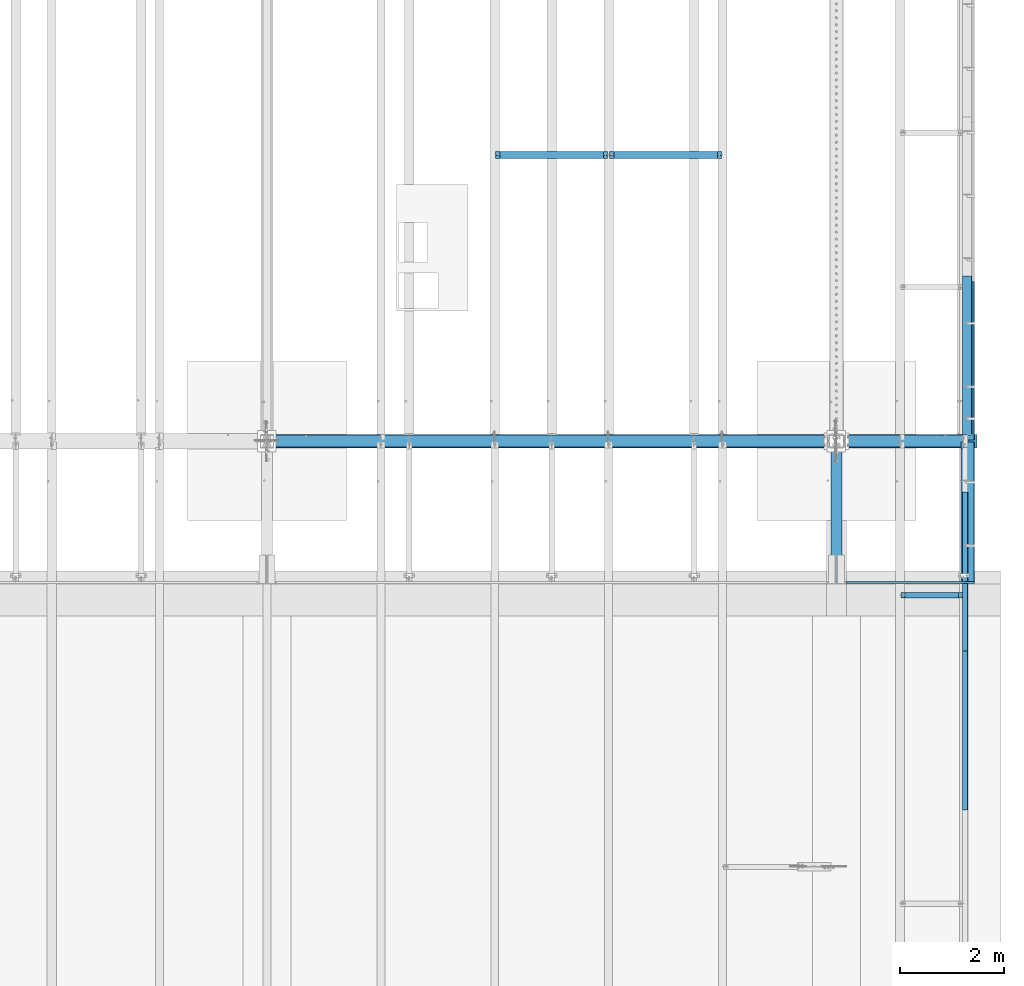
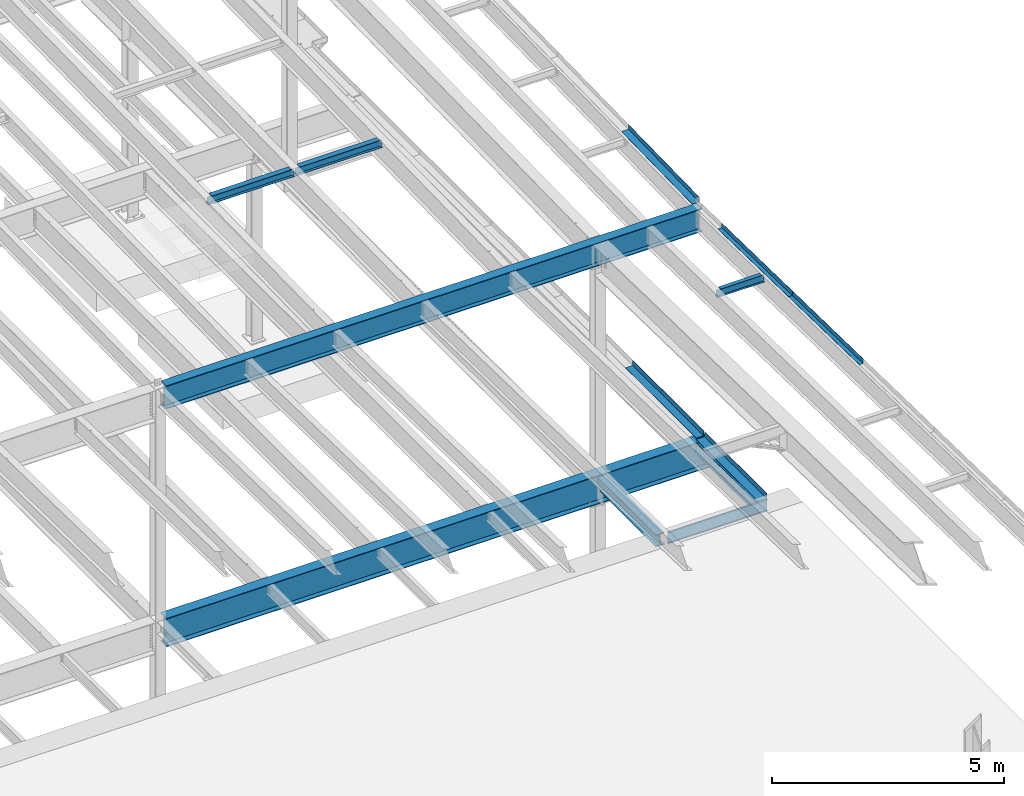
# One storey, part 1119 of 1763: 13 beams, 11 elements without a shape of their own.
"""IFC2X3 building model written with IfcOpenShell, lengths in millimetres."""

from ifc_helpers import new_model, si_unit, frame, origin_with_axes, place, context, subcontext, project, spatial, faceted_brep, material, type_object, element, aggregate, save


model = new_model("IFC2X3")

# Units and contexts
model_context = context("Model", 3, precision=1e-05, world=origin_with_axes())
body_context = subcontext(model_context, "Body", "Model", "MODEL_VIEW")
ifc_project = project(units=[si_unit("LENGTHUNIT", "METRE", prefix="MILLI"), si_unit("AREAUNIT", "SQUARE_METRE"), si_unit("VOLUMEUNIT", "CUBIC_METRE"), si_unit("MASSUNIT", "GRAM", prefix="KILO"), si_unit("TIMEUNIT", "SECOND"), si_unit("PLANEANGLEUNIT", "RADIAN"), si_unit("SOLIDANGLEUNIT", "STERADIAN"), si_unit("THERMODYNAMICTEMPERATUREUNIT", "DEGREE_CELSIUS"), si_unit("LUMINOUSINTENSITYUNIT", "LUMEN")], contexts=[model_context])

# Site, building, storey
site_placement = place(None, origin_with_axes())
site = spatial("IfcSite", under=ifc_project, at=site_placement, CompositionType="ELEMENT")
building_placement = place(site_placement, origin_with_axes())
building = spatial("IfcBuilding", under=site, at=building_placement, Name="Undefined", CompositionType="ELEMENT")
storey_placement = place(building_placement, origin_with_axes())
storey = spatial("IfcBuildingStorey", under=building, at=storey_placement, Name="Undefined", CompositionType="ELEMENT", Elevation=0.0)

# Assembly, beam
assembly_1_placement = place(storey_placement, origin_with_axes())
assembly_1 = element("IfcElementAssembly", 1, at=assembly_1_placement, inside=storey, Name="BEAM", AssemblyPlace="NOTDEFINED", PredefinedType="RIGID_FRAME")
ifc_material_1 = material(Name="STEEL/A992")
beam_type_1 = type_object("IfcBeamType", Name="W8X18", PredefinedType="NOTDEFINED")
beam_1_placement = place(assembly_1_placement, frame((-28396.6372736984, 35509.2, 11300.6242220873), z_axis=(0.0, 0.0, 1.0), x_axis=(1.0, 0.0, 0.0)))
beam_1 = element("IfcBeam", 2, at=beam_1_placement, type_object=beam_type_1, material=ifc_material_1, Name="BEAM", ObjectType="W8X18", context=body_context, shape_type="Brep", body=[
    faceted_brep([(2088.10724382306, -3.17500000000018, 68.5472454972532), (2088.10724382306, 3.17500000000018, 68.5472454972532), (2087.24625903135, 3.17500000000291, 69.8358002989517), (2087.24625903135, -3.17500000000291, 69.8358002989517), (2092.22742029121, -3.17500000000018, 65.7942315967757), (2092.22742029121, 3.17500000000018, 65.7942315967757), (2097.08749980926, -3.17500000000018, 64.8275016741882), (2097.08749980926, 3.17500000000018, 64.8275016741882), (2166.93749999999, -3.17500000000018, 64.8275016741882), (2166.93749999999, 3.17500000000018, 64.8275016741882), (2086.51974687482, -3.17500000000291, 70.3212402021363), (2086.51974687482, 3.17500000000291, 70.3212402021363), (2083.76673297434, 3.17500000000291, 74.44141667029), (2083.76673297434, -3.17500000000291, 74.44141667029), (2082.80000305175, 3.17500000000291, 79.3014961883364), (2082.80000305175, -3.17500000000291, 79.3014961883364), (2082.80000305175, 66.6750000000002, 95.25), (2082.80000305175, 3.17500000000018, 95.25), (101.599996948244, 3.17500000000018, 95.25), (101.599996948244, 66.6750000000002, 95.25), (2082.80000305175, -66.6750000000002, 95.25), (2082.80000305175, -66.6750000000002, 103.1875), (101.599996948244, -66.6750000000002, 103.1875), (101.599996948244, -66.6750000000002, 95.25), (2082.80000305175, 66.6750000000002, 103.1875), (101.599996948244, 66.6750000000002, 103.1875), (2082.80000305175, -3.17500000000018, 95.25), (101.599996948244, -3.17500000000018, 95.25), (101.599996948236, 3.17499999999927, 79.301496189446), (101.599996948236, -3.17499999999927, 79.301496189446), (100.633267025652, 3.17499999999927, 74.4414166713996), (100.633267025652, -3.17499999999927, 74.4414166713996), (97.8802531251713, 3.17499999999927, 70.3212402032459), (97.8802531251713, -3.17499999999927, 70.3212402032459), (97.153740969894, 3.17499999999927, 69.8358003008998), (97.153740969894, -3.17499999999927, 69.8358003008998), (96.2927561769247, 3.17500000000018, 68.5472454911378), (96.2927561769247, -3.17500000000018, 68.5472454911378), (92.1725797087711, 3.17500000000018, 65.7942315906603), (92.1725797087711, -3.17500000000018, 65.7942315906603), (87.3125001907247, 3.17500000000018, 64.8275016680727), (87.3125001907247, -3.17500000000018, 64.8275016680727), (17.4624999999905, 3.17500000000018, 64.8275016680727), (17.4624999999905, -3.17500000000018, 64.8275016680727), (17.4624999999905, 3.17500000000018, -95.25), (17.4624999999905, 66.6750000000002, -95.25), (17.4624999999905, 66.6750000000002, -103.1875), (17.4624999999905, -66.6750000000002, -103.1875), (17.4624999999905, -66.6750000000002, -95.25), (17.4624999999905, -3.17500000000018, -95.25), (2166.93749999999, 3.17500000000018, -95.25), (2166.93749999999, 66.6750000000002, -95.25), (2166.93749999999, 66.6750000000002, -103.1875), (2166.93749999999, -66.6750000000002, -103.1875), (2166.93749999999, -66.6750000000002, -95.25), (2166.93749999999, -3.17500000000018, -95.25)], [[[0, 1, 2, 3]], [[4, 5, 1, 0]], [[6, 7, 5, 4]], [[8, 9, 7, 6]], [[10, 11, 12, 13]], [[13, 12, 14, 15]], [[16, 17, 18, 19]], [[20, 21, 22, 23]], [[21, 24, 25, 22]], [[24, 16, 19, 25]], [[21, 20, 26, 15, 14, 17, 16, 24]], [[26, 20, 23, 27]], [[22, 25, 19, 18, 28, 29, 27, 23]], [[29, 28, 30, 31]], [[31, 30, 32, 33]], [[33, 32, 34, 35]], [[35, 34, 36, 37]], [[37, 36, 38, 39]], [[39, 38, 40, 41]], [[41, 40, 42, 43]], [[44, 45, 46, 47, 48, 49, 43, 42]], [[45, 44, 50, 51]], [[46, 45, 51, 52]], [[47, 46, 52, 53]], [[48, 47, 53, 54]], [[49, 48, 54, 55]], [[4, 0, 3, 10, 13, 15, 26, 27, 29, 31, 33, 35, 37, 39, 41, 43, 49, 55, 8, 6]], [[11, 10, 3, 2]], [[50, 44, 42, 40, 38, 36, 34, 32, 30, 28, 18, 17, 14, 12, 11, 2, 1, 5, 7, 9]], [[55, 54, 53, 52, 51, 50, 9, 8]]]),
])
aggregate(assembly_1, [beam_1])

assembly_2_placement = place(storey_placement, origin_with_axes())
assembly_2 = element("IfcElementAssembly", 3, at=assembly_2_placement, inside=storey, Name="BEAM", AssemblyPlace="NOTDEFINED", PredefinedType="RIGID_FRAME")
beam_2_placement = place(assembly_2_placement, frame((-30581.0372736984, 35509.2, 11300.6242220873), z_axis=(0.0, 0.0, 1.0), x_axis=(1.0, 0.0, 0.0)))
beam_2 = element("IfcBeam", 4, at=beam_2_placement, type_object=beam_type_1, material=ifc_material_1, Name="BEAM", ObjectType="W8X18", context=body_context, shape_type="Brep", body=[
    faceted_brep([(2088.10724382306, -3.17500000000018, 68.5472454972532), (2088.10724382306, 3.17500000000018, 68.5472454972532), (2087.24625903135, 3.17500000000291, 69.8358002989517), (2087.24625903135, -3.17500000000291, 69.8358002989517), (2092.22742029121, -3.17500000000018, 65.7942315967757), (2092.22742029121, 3.17500000000018, 65.7942315967757), (2097.08749980926, -3.17500000000018, 64.8275016741882), (2097.08749980926, 3.17500000000018, 64.8275016741882), (2166.93749999999, -3.17500000000018, 64.8275016741882), (2166.93749999999, 3.17500000000018, 64.8275016741882), (2086.51974687482, -3.17500000000291, 70.3212402021363), (2086.51974687482, 3.17500000000291, 70.3212402021363), (2083.76673297434, 3.17500000000291, 74.44141667029), (2083.76673297434, -3.17500000000291, 74.44141667029), (2082.80000305175, 3.17500000000291, 79.3014961883364), (2082.80000305175, -3.17500000000291, 79.3014961883364), (2082.80000305175, 66.6750000000002, 95.25), (2082.80000305175, 3.17500000000018, 95.25), (101.599996948244, 3.17500000000018, 95.25), (101.599996948244, 66.6750000000002, 95.25), (2082.80000305175, -66.6750000000002, 95.25), (2082.80000305175, -66.6750000000002, 103.1875), (101.599996948244, -66.6750000000002, 103.1875), (101.599996948244, -66.6750000000002, 95.25), (2082.80000305175, 66.6750000000002, 103.1875), (101.599996948244, 66.6750000000002, 103.1875), (2082.80000305175, -3.17500000000018, 95.25), (101.599996948244, -3.17500000000018, 95.25), (101.599996948236, 3.17499999999927, 79.301496189446), (101.599996948236, -3.17499999999927, 79.301496189446), (100.633267025652, 3.17499999999927, 74.4414166713996), (100.633267025652, -3.17499999999927, 74.4414166713996), (97.8802531251713, 3.17499999999927, 70.3212402032459), (97.8802531251713, -3.17499999999927, 70.3212402032459), (97.153740969894, 3.17499999999927, 69.8358003008998), (97.153740969894, -3.17499999999927, 69.8358003008998), (96.2927561769247, 3.17500000000018, 68.5472454911378), (96.2927561769247, -3.17500000000018, 68.5472454911378), (92.1725797087711, 3.17500000000018, 65.7942315906603), (92.1725797087711, -3.17500000000018, 65.7942315906603), (87.3125001907247, 3.17500000000018, 64.8275016680727), (87.3125001907247, -3.17500000000018, 64.8275016680727), (17.4624999999905, 3.17500000000018, 64.8275016680727), (17.4624999999905, -3.17500000000018, 64.8275016680727), (17.4624999999905, 3.17500000000018, -95.25), (17.4624999999905, 66.6750000000002, -95.25), (17.4624999999905, 66.6750000000002, -103.1875), (17.4624999999905, -66.6750000000002, -103.1875), (17.4624999999905, -66.6750000000002, -95.25), (17.4624999999905, -3.17500000000018, -95.25), (2166.93749999999, 3.17500000000018, -95.25), (2166.93749999999, 66.6750000000002, -95.25), (2166.93749999999, 66.6750000000002, -103.1875), (2166.93749999999, -66.6750000000002, -103.1875), (2166.93749999999, -66.6750000000002, -95.25), (2166.93749999999, -3.17500000000018, -95.25)], [[[0, 1, 2, 3]], [[4, 5, 1, 0]], [[6, 7, 5, 4]], [[8, 9, 7, 6]], [[10, 11, 12, 13]], [[13, 12, 14, 15]], [[16, 17, 18, 19]], [[20, 21, 22, 23]], [[21, 24, 25, 22]], [[24, 16, 19, 25]], [[21, 20, 26, 15, 14, 17, 16, 24]], [[26, 20, 23, 27]], [[22, 25, 19, 18, 28, 29, 27, 23]], [[29, 28, 30, 31]], [[31, 30, 32, 33]], [[33, 32, 34, 35]], [[35, 34, 36, 37]], [[37, 36, 38, 39]], [[39, 38, 40, 41]], [[41, 40, 42, 43]], [[44, 45, 46, 47, 48, 49, 43, 42]], [[45, 44, 50, 51]], [[46, 45, 51, 52]], [[47, 46, 52, 53]], [[48, 47, 53, 54]], [[49, 48, 54, 55]], [[4, 0, 3, 10, 13, 15, 26, 27, 29, 31, 33, 35, 37, 39, 41, 43, 49, 55, 8, 6]], [[11, 10, 3, 2]], [[50, 44, 42, 40, 38, 36, 34, 32, 30, 28, 18, 17, 14, 12, 11, 2, 1, 5, 7, 9]], [[55, 54, 53, 52, 51, 50, 9, 8]]]),
])
aggregate(assembly_2, [beam_2])

# Assembly, beams
assembly_3_placement = place(storey_placement, origin_with_axes())
assembly_3 = element("IfcElementAssembly", 5, at=assembly_3_placement, inside=storey, Name="BEAM", AssemblyPlace="NOTDEFINED", PredefinedType="RIGID_FRAME")
ifc_material_2 = material(Name="STEEL/A36")
beam_type_2 = type_object("IfcBeamType", PredefinedType="NOTDEFINED")
beam_3_placement = place(assembly_3_placement, frame((-21608.4906443555, 27524.3058332851, 11345.709019807), z_axis=(0.0, -0.999781542838788, 0.0209013539966307), x_axis=(1.0, 0.0, 0.0)))
beam_3 = element("IfcBeam", 6, at=beam_3_placement, type_object=beam_type_2, material=ifc_material_2, Name="BENT_PLATE", context=body_context, shape_type="Brep", body=[
    faceted_brep([(0.0, -3.17499999999927, -1523.99999999999), (0.0, -3.17499999999927, 1524.0), (0.0, 3.17499999999927, 1524.0), (0.0, 3.17499999999927, -1523.99999999999), (95.2499984741262, 3.17499999910251, 1523.99999999978), (95.2499984741262, 3.17500000090149, -1523.99999999977), (101.599998474125, -3.17499999909887, -1523.99999999978), (101.599999809252, -3.17500000000655, 1524.0), (95.2499984741262, 123.825003587437, 1523.99999999985), (95.2499984741262, 123.825003589236, -1523.9999999997), (101.599998474125, 123.825003587437, 1523.99999999985), (101.599998474125, 123.825003589236, -1523.9999999997)], [[[0, 1, 2, 3]], [[3, 2, 4, 5]], [[1, 0, 6, 7]], [[5, 4, 8, 9]], [[4, 2, 1, 7, 10, 8]], [[7, 6, 11, 10]], [[6, 0, 3, 5, 9, 11]], [[10, 11, 9, 8]]]),
])
beam_4_placement = place(assembly_3_placement, frame((-21608.4906443555, 24476.9716909039, 11409.416355927), z_axis=(0.0, -0.999781542838788, 0.0209013539966307), x_axis=(1.0, 0.0, 0.0)))
beam_4 = element("IfcBeam", 7, at=beam_4_placement, type_object=beam_type_2, material=ifc_material_2, Name="BENT_PLATE", context=body_context, shape_type="Brep", body=[
    faceted_brep([(0.0, -3.17499999999927, -1523.99999999999), (0.0, -3.17499999999927, 1524.0), (0.0, 3.17499999999927, 1524.0), (0.0, 3.17499999999927, -1523.99999999999), (95.2499984741262, 3.17499999910251, 1523.99999999978), (95.2499984741262, 3.17500000090149, -1523.99999999977), (101.599998474125, -3.17499999909887, -1523.99999999978), (101.599999809252, -3.17500000000655, 1524.0), (95.2499984741262, 123.825003587437, 1523.99999999985), (95.2499984741262, 123.825003589236, -1523.9999999997), (101.599998474125, 123.825003587437, 1523.99999999985), (101.599998474125, 123.825003589236, -1523.9999999997)], [[[0, 1, 2, 3]], [[3, 2, 4, 5]], [[1, 0, 6, 7]], [[5, 4, 8, 9]], [[4, 2, 1, 7, 10, 8]], [[7, 6, 11, 10]], [[6, 0, 3, 5, 9, 11]], [[10, 11, 9, 8]]]),
])
aggregate(assembly_3, [beam_3, beam_4])

# Assembly, beam
assembly_4_placement = place(storey_placement, origin_with_axes())
assembly_4 = element("IfcElementAssembly", 8, at=assembly_4_placement, inside=storey, Name="BEAM", AssemblyPlace="NOTDEFINED", PredefinedType="RIGID_FRAME")
beam_type_3 = type_object("IfcBeamType", Name="W8X10", PredefinedType="NOTDEFINED")
beam_5_placement = place(assembly_4_placement, frame((-22808.6484080275, 27066.2368713979, 11252.0971809705), z_axis=(0.0, 0.0, 1.0), x_axis=(1.0, 0.0, 0.0)))
beam_5 = element("IfcBeam", 9, at=beam_5_placement, type_object=beam_type_3, material=ifc_material_1, Name="BEAM", ObjectType="W8X10", context=body_context, shape_type="Brep", body=[
    faceted_brep([(1119.19526367187, -50.7999999999993, 100.012500000001), (1119.19526367187, -50.7999999999993, 95.25), (1119.19526367187, -2.38124999999854, 95.25), (1119.19526367187, -2.38124999999854, 83.877501483119), (1119.19526367187, 2.38124999999854, 83.877501483119), (1119.19526367187, 2.38124999999854, 95.25), (1119.19526367187, 50.7999999999993, 95.25), (1119.19526367187, 50.7999999999993, 100.012500000001), (1120.16199359446, -2.38124999999854, 79.0174219650726), (1120.16199359446, 2.38124999999854, 79.0174219650726), (1122.91500749494, -2.38124999999854, 74.8972454969189), (1122.91500749494, 2.38124999999854, 74.8972454969189), (1127.03518396309, -2.38124999999854, 72.1442315964414), (1127.03518396309, 2.38124999999854, 72.1442315964414), (1131.89526348114, -2.38124999999854, 71.1775016738538), (1131.89526348114, 2.38124999999854, 71.1775016738538), (1201.74526367187, -2.38124999999854, 71.1775016738538), (1201.74526367187, 2.38124999999854, 71.1775016738538), (100.012500000012, -50.7999999999993, 100.012500000001), (100.012500000012, 50.7999999999993, 100.012500000001), (100.012500000012, 50.7999999999993, 95.25), (100.012500000012, 2.38124999999854, 95.25), (100.012500000012, 2.38124999999854, 83.877501483119), (100.012500000012, -2.38124999999854, 83.877501483119), (100.012500000012, -2.38124999999854, 95.25), (100.012500000012, -50.7999999999993, 95.25), (99.0457700774241, 2.38124999999854, 79.0174219650726), (99.0457700774241, -2.38124999999854, 79.0174219650726), (96.2927561769466, 2.38124999999854, 74.8972454969189), (96.2927561769466, -2.38124999999854, 74.8972454969189), (92.1725797087929, 2.38124999999854, 72.1442315964414), (92.1725797087929, -2.38124999999854, 72.1442315964414), (87.3125001907465, 2.38124999999854, 71.1775016738538), (87.3125001907465, -2.38124999999854, 71.1775016738538), (17.4625000000015, 2.38124999999854, 71.1775016738538), (17.4625000000015, -2.38124999999854, 71.1775016738538), (17.462499935149, 2.38124999999854, -95.25), (17.4625000000015, 50.7999999999993, -95.25), (17.4625000000015, 50.7999999999993, -100.012500000001), (17.4624996160601, -50.8000000000029, -100.012500000001), (17.4624996160601, -50.8000000000029, -95.25), (17.4624999065727, -2.38124999999854, -95.25), (1201.74526367187, 2.38124999999854, -95.25), (1201.74526367187, 50.7999999999993, -95.25), (1201.74526367187, 50.7999999999993, -100.012500000001), (1201.74526367187, -50.7999999999993, -100.012500000001), (1201.74526367187, -50.7999999999993, -95.25), (1201.74526367187, -2.38124999999854, -95.25)], [[[0, 1, 2, 3, 4, 5, 6, 7]], [[8, 9, 4, 3]], [[10, 11, 9, 8]], [[12, 13, 11, 10]], [[14, 15, 13, 12]], [[16, 17, 15, 14]], [[18, 19, 20, 21, 22, 23, 24, 25]], [[23, 22, 26, 27]], [[27, 26, 28, 29]], [[29, 28, 30, 31]], [[31, 30, 32, 33]], [[33, 32, 34, 35]], [[36, 37, 38, 39, 40, 41, 35, 34]], [[37, 36, 42, 43]], [[38, 37, 43, 44]], [[39, 38, 44, 45]], [[40, 39, 45, 46]], [[41, 40, 46, 47]], [[12, 10, 8, 3, 2, 24, 23, 27, 29, 31, 33, 35, 41, 47, 16, 14]], [[25, 24, 2, 1]], [[18, 25, 1, 0]], [[19, 18, 0, 7]], [[20, 19, 7, 6]], [[21, 20, 6, 5]], [[42, 36, 34, 32, 30, 28, 26, 22, 21, 5, 4, 9, 11, 13, 15, 17]], [[47, 46, 45, 44, 43, 42, 17, 16]]]),
])
aggregate(assembly_4, [beam_5])

assembly_5_placement = place(storey_placement, origin_with_axes())
assembly_5 = element("IfcElementAssembly", 10, at=assembly_5_placement, inside=storey, Name="BEAM", AssemblyPlace="NOTDEFINED", PredefinedType="RIGID_FRAME")
beam_type_4 = type_object("IfcBeamType", PredefinedType="NOTDEFINED")
beam_6_placement = place(assembly_5_placement, frame((-21595.7872736984, 28667.075, 5199.0625), z_axis=(0.0, -1.0, 0.0), x_axis=(1.0, 0.0, 0.0)))
beam_6 = element("IfcBeam", 11, at=beam_6_placement, type_object=beam_type_4, material=ifc_material_2, Name="BENT_PLATE", context=body_context, shape_type="Brep", body=[
    faceted_brep([(0.0, -4.76249999999982, -1336.675), (0.0, -4.76249999999982, 1336.675), (0.0, 4.76249999999982, 1336.675), (0.0, 4.76249999999982, -1336.675), (209.549996948241, 4.76249999999982, 1336.675), (209.549996948241, 4.76249999999982, -1336.675), (219.074996948242, -4.76249999999982, -1336.675), (219.074996948242, -4.76249999999982, 1336.675), (209.549996948241, 134.937496948242, 1336.675), (209.549996948241, 134.937496948242, -1336.675), (219.074996948242, 134.937496948242, 1336.675), (219.074996948242, 134.937496948242, -1336.675)], [[[0, 1, 2, 3]], [[3, 2, 4, 5]], [[1, 0, 6, 7]], [[5, 4, 8, 9]], [[4, 2, 1, 7, 10, 8]], [[7, 6, 11, 10]], [[6, 0, 3, 5, 9, 11]], [[10, 11, 9, 8]]]),
])

assembly_6_placement = place(storey_placement, origin_with_axes())
assembly_6 = element("IfcElementAssembly", 12, at=assembly_6_placement, inside=storey, Name="BEAM", AssemblyPlace="NOTDEFINED", PredefinedType="RIGID_FRAME")
beam_type_5 = type_object("IfcBeamType", PredefinedType="NOTDEFINED")
beam_7_placement = place(assembly_6_placement, frame((-21564.0372736984, 31565.85, 5199.0625), z_axis=(0.0, -1.0, 0.0), x_axis=(1.0, 0.0, 0.0)))
beam_7 = element("IfcBeam", 13, at=beam_7_placement, type_object=beam_type_5, material=ifc_material_2, Name="BENT_PLATE", context=body_context, shape_type="Brep", body=[
    faceted_brep([(0.0, -4.76249999999982, -1524.0), (0.0, -4.76249999999982, 1524.0), (0.0, 4.76249999999982, 1524.0), (0.0, 4.76249999999982, -1524.0), (177.799996948241, 4.76249999999982, 1524.0), (177.799996948241, 4.76249999999982, -1524.0), (187.324996948242, -4.76249999999982, -1524.0), (187.324996948242, -4.76249999999982, 1524.0), (177.799996948241, 134.937496948242, 1524.0), (177.799996948241, 134.937496948242, -1524.0), (187.324996948242, 134.937496948242, 1524.0), (187.324996948242, 134.937496948242, -1524.0)], [[[0, 1, 2, 3]], [[3, 2, 4, 5]], [[1, 0, 6, 7]], [[5, 4, 8, 9]], [[4, 2, 1, 7, 10, 8]], [[7, 6, 11, 10]], [[6, 0, 3, 5, 9, 11]], [[10, 11, 9, 8]]]),
])
aggregate(assembly_6, [beam_7])

assembly_7_placement = place(storey_placement, origin_with_axes())
assembly_7 = element("IfcElementAssembly", 14, at=assembly_7_placement, inside=storey, Name="BEAM", AssemblyPlace="NOTDEFINED", PredefinedType="RIGID_FRAME")
beam_type_6 = type_object("IfcBeamType", PredefinedType="NOTDEFINED")
beam_8_placement = place(assembly_7_placement, frame((-21608.4906443556, 31668.1035664276, 11327.5164422989), z_axis=(0.0, -0.999786037781472, -0.0206852279954809), x_axis=(1.0, 0.0, 0.0)))
beam_8 = element("IfcBeam", 15, at=beam_8_placement, type_object=beam_type_6, material=ifc_material_2, Name="BENT_PLATE", context=body_context, shape_type="Brep", body=[
    faceted_brep([(0.0, -3.17499999999927, -1523.99999999999), (0.0, -3.17499999999927, 1524.0), (0.0, 3.17499999999927, 1524.0), (0.0, 3.17499999999927, -1523.99999999999), (174.625006103754, 3.17500000029031, 1523.99999999885), (174.625006103754, 3.17499999971005, -1523.99999999885), (180.975006103752, -3.17500000028485, -1523.99999999885), (180.975006103752, -3.17499999970642, 1523.99999999885), (174.625006103754, 123.824997298747, 1523.99999999882), (174.625006103754, 123.824997298168, -1523.99999999888), (180.975006103752, 123.824997298747, 1523.99999999882), (180.975006103752, 123.824997298168, -1523.99999999888)], [[[0, 1, 2, 3]], [[3, 2, 4, 5]], [[1, 0, 6, 7]], [[5, 4, 8, 9]], [[4, 2, 1, 7, 10, 8]], [[7, 6, 11, 10]], [[6, 0, 3, 5, 9, 11]], [[10, 11, 9, 8]]]),
])
aggregate(assembly_7, [beam_8])

# Beam
beam_type_7 = type_object("IfcBeamType", Name="W12X16", PredefinedType="NOTDEFINED")
beam_9_placement = place(assembly_5_placement, frame((-21589.4372736984, 27330.4, 5041.9), z_axis=(0.0, 0.0, 1.0), x_axis=(0.0, 1.0, 0.0)))
beam_9 = element("IfcBeam", 16, at=beam_9_placement, type_object=beam_type_7, material=ifc_material_1, Name="BEAM", ObjectType="W12X16", context=body_context, shape_type="Brep", body=[
    faceted_brep([(12.7000000000007, -3.17499999999927, -146.05), (12.7000000000007, -50.7999999999993, -146.05), (2673.35000000001, -50.7999999999993, -146.05), (2673.35000000001, -3.17499999999927, -146.05), (12.7000000000007, -50.7999999999993, -152.4), (2673.35000000001, -50.7999999999993, -152.4), (12.7000000000007, 50.7999999999993, -152.4), (2673.35000000001, 50.7999999999993, -152.4), (12.7000000000007, 50.7999999999993, -146.05), (12.7000000000007, 3.17499999999927, -146.05), (2673.35000000001, 3.17499999999927, -146.05), (2673.35000000001, 50.7999999999993, -146.05), (2673.35000000001, 3.17499999999927, 120.390001678466), (2673.35000000001, -3.17499999999927, 120.390001678466), (12.7000000000007, -3.17499999999927, 146.05), (12.7000000000007, -50.7999999999993, 146.05), (12.7000000000007, -50.7999999999993, 152.4), (12.7000000000007, 50.7999999999993, 152.4), (12.7000000000007, 50.7999999999993, 146.05), (12.7000000000007, 3.17499999999927, 146.05), (2546.35000000001, 50.7999999999993, 146.05), (2546.35000000001, 3.17499999999927, 146.05), (2546.35000000001, 3.17499999999927, 133.090001487731), (2547.31672992259, 3.17499999999927, 128.229921969685), (2550.06974382307, 3.17499999999927, 124.109745501532), (2554.18992029122, 3.17499999999927, 121.356731601053), (2559.04999980927, 3.17499999999927, 120.390001678466), (2547.31672992259, -3.17499999999927, 128.229921969685), (2546.35000000001, -3.17499999999927, 133.090001487731), (2550.06974382307, -3.17499999999927, 124.109745501532), (2554.18992029122, -3.17499999999927, 121.356731601053), (2559.04999980927, -3.17499999999927, 120.390001678466), (2546.35000000001, -3.17499999999927, 146.05), (2546.35000000001, -50.7999999999993, 146.05), (2546.35000000001, -50.7999999999993, 152.4), (2546.35000000001, 50.7999999999993, 152.4)], [[[0, 1, 2, 3]], [[1, 4, 5, 2]], [[4, 6, 7, 5]], [[8, 9, 10, 11]], [[3, 2, 5, 7, 11, 10, 12, 13]], [[6, 8, 11, 7]], [[4, 1, 0, 14, 15, 16, 17, 18, 19, 9, 8, 6]], [[19, 18, 20, 21]], [[10, 9, 19, 21, 22, 23, 24, 25, 26, 12]], [[27, 23, 22, 28]], [[29, 24, 23, 27]], [[30, 25, 24, 29]], [[31, 26, 25, 30]], [[13, 12, 26, 31]], [[30, 29, 27, 28, 32, 14, 0, 3, 13, 31]], [[15, 14, 32, 33]], [[16, 15, 33, 34]], [[17, 16, 34, 35]], [[18, 17, 35, 20]], [[34, 33, 32, 28, 22, 21, 20, 35]]]),
])

aggregate(assembly_5, [beam_6, beam_9])

# Assembly, beam
assembly_8_placement = place(storey_placement, origin_with_axes())
assembly_8 = element("IfcElementAssembly", 17, at=assembly_8_placement, inside=storey, Name="BEAM", AssemblyPlace="NOTDEFINED", PredefinedType="RIGID_FRAME")
beam_type_8 = type_object("IfcBeamType", Name="W24X76", PredefinedType="NOTDEFINED")
beam_10_placement = place(assembly_8_placement, frame((-34949.8372736984, 30022.8000001452, 10987.0874999952), z_axis=(0.0, 0.0, 1.0), x_axis=(1.0, 0.0, 0.0)))
beam_10 = element("IfcBeam", 18, at=beam_10_placement, type_object=beam_type_8, material=ifc_material_1, Name="BEAM", ObjectType="W24X76", context=body_context, shape_type="Brep", body=[
    faceted_brep([(141.287499999999, 114.299999999999, -303.2125), (141.287499999999, 114.299999999999, -285.75), (13449.3046875, 114.299999999999, -285.75), (13449.3046875, 114.299999999999, -303.2125), (141.287499999999, 5.55625000000146, -285.75), (13449.3046875, 5.55625000000146, -285.75), (141.287499999999, 5.55625000000146, 285.75), (13449.3046875, 5.55625000000146, 285.75), (141.287499999999, 114.299999999999, 285.75), (13449.3046875, 114.299999999999, 285.75), (141.287499999999, 114.299999999999, 303.2125), (13449.3046875, 114.299999999999, 303.2125), (141.287499999999, -114.299999999999, 303.2125), (13449.3046875, -114.299999999999, 303.2125), (141.287499999999, -114.299999999999, 285.75), (13449.3046875, -114.299999999999, 285.75), (141.287499999999, -5.55625000000146, 285.75), (13449.3046875, -5.55625000000146, 285.75), (141.287499999999, -5.55625000000146, -285.75), (13449.3046875, -5.55625000000146, -285.75), (141.287499999999, -114.299999999999, -285.75), (13449.3046875, -114.299999999999, -285.75), (141.287499999999, -114.299999999999, -303.2125), (13449.3046875, -114.299999999999, -303.2125)], [[[0, 1, 2, 3]], [[1, 4, 5, 2]], [[4, 6, 7, 5]], [[6, 8, 9, 7]], [[8, 10, 11, 9]], [[10, 12, 13, 11]], [[12, 14, 15, 13]], [[14, 16, 17, 15]], [[16, 18, 19, 17]], [[18, 20, 21, 19]], [[20, 22, 23, 21]], [[22, 0, 3, 23]], [[5, 7, 9, 11, 13, 15, 17, 19, 21, 23, 3, 2]], [[22, 20, 18, 16, 14, 12, 10, 8, 6, 4, 1, 0]]]),
])
aggregate(assembly_8, [beam_10])

assembly_9_placement = place(storey_placement, origin_with_axes())
assembly_9 = element("IfcElementAssembly", 19, at=assembly_9_placement, inside=storey, Name="BEAM", AssemblyPlace="NOTDEFINED", PredefinedType="RIGID_FRAME")
beam_type_9 = type_object("IfcBeamType", Name="W30X90", PredefinedType="NOTDEFINED")
beam_11_placement = place(assembly_9_placement, frame((-34949.8372736984, 30022.8, 4819.65), z_axis=(0.0, 0.0, 1.0), x_axis=(1.0, 0.0, 0.0)))
beam_11 = element("IfcBeam", 20, at=beam_11_placement, type_object=beam_type_9, material=ifc_material_1, Name="BEAM", ObjectType="W30X90", context=body_context, shape_type="Brep", body=[
    faceted_brep([(141.287500000006, 131.762500000001, -374.65), (141.287500000006, 131.762500000001, -358.775), (13620.75, 131.762499999997, -358.775), (13620.75, 131.762499999997, -374.65), (141.287500000006, 6.34999999999854, -358.775), (13620.75, 6.34999999999854, -358.775), (141.287500000006, 6.34999999999854, 358.775), (13620.75, 6.34999999999854, 358.775), (141.287500000006, 131.762500000001, 358.775), (13620.75, 131.762499999997, 358.775), (141.287500000006, 131.762500000001, 374.65), (13620.75, 131.762499999997, 374.65), (141.287500000006, -131.762500000001, 374.65), (13620.75, -131.762499999997, 374.65), (141.287500000006, -131.762500000001, 358.775), (13620.75, -131.762499999997, 358.775), (141.287500000006, -6.34999999999854, 358.775), (13620.75, -6.34999999999854, 358.775), (141.287500000006, -6.34999999999854, -358.775), (13620.75, -6.34999999999854, -358.775), (141.287500000006, -131.762500000001, -358.775), (13620.75, -131.762499999997, -358.775), (141.287500000006, -131.762500000001, -374.65), (13620.75, -131.762499999997, -374.65)], [[[0, 1, 2, 3]], [[1, 4, 5, 2]], [[4, 6, 7, 5]], [[6, 8, 9, 7]], [[8, 10, 11, 9]], [[10, 12, 13, 11]], [[12, 14, 15, 13]], [[14, 16, 17, 15]], [[16, 18, 19, 17]], [[18, 20, 21, 19]], [[20, 22, 23, 21]], [[22, 0, 3, 23]], [[5, 7, 9, 11, 13, 15, 17, 19, 21, 23, 3, 2]], [[22, 20, 18, 16, 14, 12, 10, 8, 6, 4, 1, 0]]]),
])
aggregate(assembly_9, [beam_11])

assembly_10_placement = place(storey_placement, origin_with_axes())
assembly_10 = element("IfcElementAssembly", 21, at=assembly_10_placement, inside=storey, Name="BEAM", AssemblyPlace="NOTDEFINED", PredefinedType="RIGID_FRAME")
beam_type_10 = type_object("IfcBeamType", Name="MC12X10.6", PredefinedType="NOTDEFINED")
beam_12_placement = place(assembly_10_placement, frame((-23845.2747736984, 27311.35, 5041.9), z_axis=(0.0, 0.0, 1.0), x_axis=(1.0, 0.0, 0.0)))
beam_12 = element("IfcBeam", 22, at=beam_12_placement, type_object=beam_type_10, material=ifc_material_1, Name="BEAM", ObjectType="MC12X10.6", context=body_context, shape_type="Brep", body=[
    faceted_brep([(0.0, 19.0499999999993, -152.4), (0.0, 19.0499999999993, 152.4), (2468.56249694825, 19.0499999999993, 152.4), (2468.56249694825, 19.0499999999993, -152.4), (0.0, -19.0499999999993, 152.4), (2468.56249694825, -19.0499999999993, 152.4), (0.0, -19.0499999999993, 144.841595), (2468.56249694825, -19.0499999999993, 144.841595), (0.0, 14.2874999999985, 144.17817875), (2468.56249694825, 14.2874999999985, 144.17817875), (0.0, 14.2874999999985, -144.17817875), (2468.56249694825, 14.2874999999985, -144.17817875), (0.0, -19.0499999999993, -144.841595), (2468.56249694825, -19.0499999999993, -144.841595), (0.0, -19.0499999999993, -152.4), (2468.56249694825, -19.0499999999993, -152.4)], [[[0, 1, 2, 3]], [[1, 4, 5, 2]], [[4, 6, 7, 5]], [[6, 8, 9, 7]], [[8, 10, 11, 9]], [[10, 12, 13, 11]], [[12, 14, 15, 13]], [[14, 0, 3, 15]], [[5, 7, 9, 11, 13, 15, 3, 2]], [[14, 12, 10, 8, 6, 4, 1, 0]]]),
])
aggregate(assembly_10, [beam_12])

assembly_11_placement = place(storey_placement, origin_with_axes())
assembly_11 = element("IfcElementAssembly", 23, at=assembly_11_placement, inside=storey, Name="BEAM", AssemblyPlace="NOTDEFINED", PredefinedType="RIGID_FRAME")
beam_type_11 = type_object("IfcBeamType", Name="W12X50", PredefinedType="NOTDEFINED")
beam_13_placement = place(assembly_11_placement, frame((-24027.8372736984, 27279.6, 5038.725), z_axis=(0.0, 0.0, 1.0), x_axis=(0.0, 1.0, 0.0)))
beam_13 = element("IfcBeam", 24, at=beam_13_placement, type_object=beam_type_11, material=ifc_material_1, Name="BEAM", ObjectType="W12X50", context=body_context, shape_type="Brep", body=[
    faceted_brep([(2470.14992464257, 4.76250000000073, -139.7), (2470.14992464274, 4.76212718450552, -155.575), (2470.14989796943, 103.1875, -155.575), (2470.14989796943, 103.1875, -139.7), (2724.15, 4.76250000000073, -139.7), (2724.15, 4.7621960186043, -155.575), (50.7999999999993, -4.76250000000073, -139.7), (50.7999999999993, -103.1875, -139.7), (2470.14999864682, -103.1875, -139.7), (2470.14997197366, -4.76250000000073, -139.7), (50.7999999999993, 4.76250000000073, 139.7), (50.7999999999993, 103.1875, 139.7), (2571.75, 103.1875, 139.7), (2571.75, 4.76250000000073, 139.7), (50.7999999999993, -103.1875, -155.575), (50.7999999999993, -4.76250000000073, 139.7), (50.7999999999993, -103.1875, 139.7), (50.7999999999993, -103.1875, 155.575), (50.7999999999993, 103.1875, 155.575), (50.7999999999993, 4.76250000000073, -139.7), (50.7999999999993, 103.1875, -139.7), (50.7999999999993, 103.1875, -155.575), (2470.14999864682, -103.1875, -155.575), (2470.14997197383, -4.76286670557602, -155.575), (2724.15, -4.76250000000073, -139.7), (2724.15, -4.76279787149178, -155.575), (2579.58992029122, -4.76250000000073, 124.791729922586), (2575.46974382307, -4.76250000000073, 127.544743823065), (2572.71672992259, -4.76250000000073, 131.664920291219), (2571.75, -4.76250000000073, 136.524999809264), (2571.75, -4.76250000000073, 139.7), (2724.15, -4.76250000000073, -127.829586330973), (2724.15, -4.76250000000073, 123.824999999999), (2584.44999980927, -4.76250000000073, 123.824999999999), (2571.75, -103.1875, 139.7), (2571.75, -103.1875, 155.575), (2571.75, 103.1875, 155.575), (2571.75, 4.76250000000073, 136.524999809264), (2572.71672992259, 4.76250000000073, 131.664920291219), (2575.46974382307, 4.76250000000073, 127.544743823065), (2579.58992029122, 4.76250000000073, 124.791729922586), (2584.44999980927, 4.76250000000073, 123.824999999999), (2724.15, 4.76250000000073, 123.824999999999), (2724.15, 4.76250000000073, -127.830030179034)], [[[0, 1, 2, 3]], [[4, 5, 1, 0]], [[6, 7, 8, 9]], [[10, 11, 12, 13]], [[14, 7, 6, 15, 16, 17, 18, 11, 10, 19, 20, 21]], [[7, 14, 22, 8]], [[8, 22, 23, 9]], [[24, 9, 23, 25]], [[26, 27, 28, 29, 30, 15, 6, 9, 24, 31, 32, 33]], [[16, 15, 30, 34]], [[17, 16, 34, 35]], [[18, 17, 35, 36]], [[11, 18, 36, 12]], [[35, 34, 30, 29, 37, 13, 12, 36]], [[28, 38, 37, 29]], [[27, 39, 38, 28]], [[26, 40, 39, 27]], [[33, 41, 40, 26]], [[32, 42, 41, 33]], [[43, 4, 0, 19, 10, 13, 37, 38, 39, 40, 41, 42]], [[20, 19, 0, 3]], [[21, 20, 3, 2]], [[25, 23, 22, 14, 21, 2, 1, 5]], [[43, 42, 32, 31, 24, 25, 5, 4]]]),
])
aggregate(assembly_11, [beam_13])

save(model, "model.ifc")
